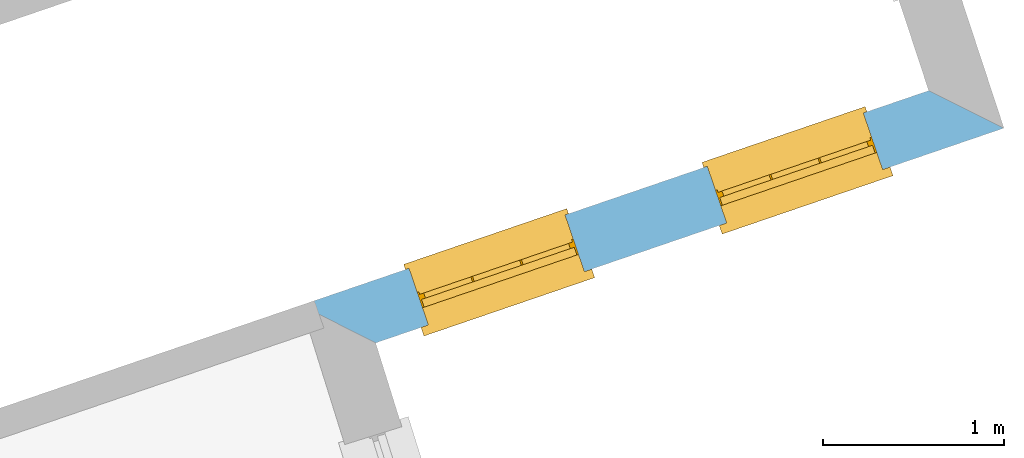
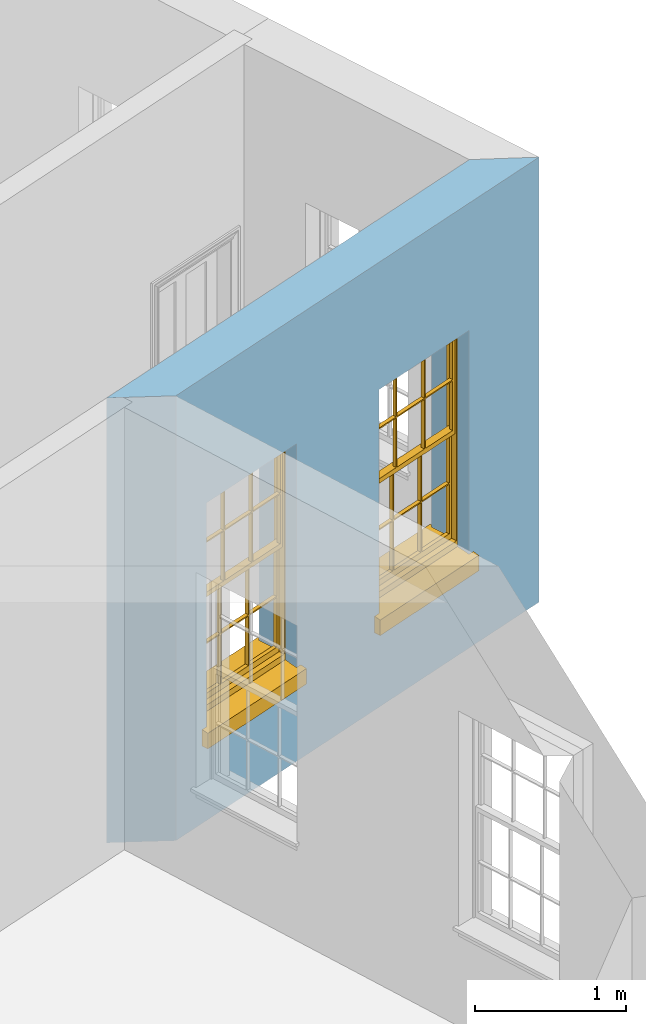
# One storey, part 5 of 10: 2 windows, 2 openings, plus 1 element that does not belong to this part.
"""IFC2X3 building model written with IfcOpenShell, lengths in metres."""

from ifc_helpers import new_model, si_unit, frame, origin, place, context, subcontext, project, spatial, polyline, outline, extrude, faceted_brep, material, layer, layer_set, layer_usage, element, fill, save


model = new_model("IFC2X3")

# Units and contexts
model_context = context("Model", 3, world=origin())
body_context = subcontext(model_context, "Body", "Model", "MODEL_VIEW")
ifc_project = project(units=[si_unit("PLANEANGLEUNIT", "RADIAN"), si_unit("MASSUNIT", "GRAM", prefix="KILO"), si_unit("FORCEUNIT", "NEWTON", prefix="KILO"), si_unit("LENGTHUNIT", "METRE")], contexts=[model_context])

# Site, building, storey
site_placement = place(None, origin())
site = spatial("IfcSite", under=ifc_project, at=site_placement, CompositionType="ELEMENT")
building_placement = place(None, origin())
building = spatial("IfcBuilding", under=site, at=building_placement, Name="Building plot-2", CompositionType="ELEMENT")
storey_placement = place(None, frame((0.0, 0.0, 4.6)))
storey = spatial("IfcBuildingStorey", under=building, at=storey_placement, Name="Floor 1", CompositionType="ELEMENT", Elevation=4.6)

# Wall, openings, windows
ifc_material = material(Name="Masonry")
ifc_layer = layer(ifc_material, 0.33, ventilated=False)
ifc_layer_set = layer_set([ifc_layer], Name="My Wall")
ifc_layer_usage = layer_usage(ifc_layer_set, "AXIS2", "NEGATIVE", 0.08)
wall_placement = place(storey_placement, origin())
wall = element("IfcWallStandardCase", 1, at=wall_placement, inside=storey, material=ifc_layer_usage, Name="exterior", context=body_context, shape_type="SweptSolid", body=[
    extrude(outline(polyline([(33.2298586094676, 32.7296307023118), (33.6407893243681, 32.5213803227765), (37.1047195485034, 33.7057805140381), (36.6893138301649, 33.9125007833851), (33.2298586094676, 32.7296307023118)])), origin(), (0.0, 0.0, 1.0), 3.6),
])
opening_1_placement = place(storey_placement, frame((0.0, 0.0, 0.75)))
opening_1 = element("IfcOpeningElement", 2, at=opening_1_placement, cuts=wall, Name="Opening", ObjectType="Opening", context=body_context, shape_type="SweptSolid", body=[
    extrude(outline(polyline([(33.9307807744007, 32.620535301849), (34.7918378423025, 32.9149512080368), (34.6850716345641, 33.2272026722209), (33.8240145666623, 32.9327867660332), (33.9307807744007, 32.620535301849)])), origin(), (0.0, 0.0, 1.0), 1.82),
])
opening_2_placement = place(storey_placement, frame((0.0, 0.0, 0.75)))
opening_2 = element("IfcOpeningElement", 3, at=opening_2_placement, cuts=wall, Name="Opening", ObjectType="Opening", context=body_context, shape_type="SweptSolid", body=[
    extrude(outline(polyline([(35.5752381859879, 33.1828144318484), (36.4362952538897, 33.4772303380362), (36.3295290461513, 33.7894818022204), (35.4684719782495, 33.4950658960326), (35.5752381859879, 33.1828144318484)])), origin(), (0.0, 0.0, 1.0), 1.82),
])
window_1_placement = place(storey_placement, frame((33.8498972836898, 32.8570894413824, 0.75), z_axis=(0.0, 0.0, 1.0), x_axis=(0.86105706790179, 0.294415906187787, 0.0)))
window_1 = element("IfcWindow", 4, at=window_1_placement, inside=storey, Name="circulation outside window", OverallHeight=1.82, OverallWidth=0.91, context=body_context, shape_type="Brep", held_by="IfcProductRepresentation", body=[
    faceted_brep([(0.033125, -0.105, 0.975209), (0.01, -0.105, 0.975209), (0.033125, -0.105, 1.376042), (0.876875, -0.105, 0.975209), (0.876875, -0.105, 1.376042), (0.9, -0.105, 0.975209), (0.876875, -0.105, 1.386042), (0.876875, -0.105, 1.786875), (0.9, -0.105, 1.81), (0.033125, -0.105, 1.786875), (0.033125, -0.105, 1.386042), (0.01, -0.105, 1.81), (0.876875, -0.135, 1.376042), (0.876875, -0.135, 0.975209), (0.9, -0.135, 0.937083), (0.033125, -0.135, 1.786875), (0.01, -0.135, 1.81), (0.033125, -0.135, 1.386042), (0.01, -0.135, 0.937083), (0.033125, -0.135, 0.975209), (0.033125, -0.135, 1.376042), (0.876875, -0.135, 1.786875), (0.876875, -0.135, 1.386042), (0.9, -0.135, 1.81), (0.033125, -0.105, 0.937083), (0.01, -0.105, 0.937083), (0.033125, -0.105, 0.53625), (0.876875, -0.105, 0.937083), (0.876875, -0.105, 0.53625), (0.9, -0.105, 0.937083), (0.876875, -0.105, 0.52625), (0.876875, -0.105, 0.125417), (0.9, -0.105, 0.077167), (0.033125, -0.105, 0.125417), (0.033125, -0.105, 0.52625), (0.01, -0.105, 0.077167), (-0.0425, -0.25, 0.01), (-0.0425, -0.3, 0.001667), (0.0, -0.25, 0.01), (0.9525, -0.25, 0.01), (0.91, -0.25, 0.01), (0.9525, -0.3, 0.001667), (-0.02, 0.08, 0.077167), (0.0, 0.08, 0.077167), (-0.02, 0.11, 0.077167), (0.0, -0.06, 0.077167), (0.01, -0.06, 0.077167), (0.91, -0.06, 0.077167), (0.91, 0.08, 0.077167), (0.9, -0.06, 0.077167), (0.93, 0.08, 0.077167), (0.93, 0.11, 0.077167), (0.01, -0.075, 0.975209), (0.9, -0.075, 0.975209), (0.876875, -0.075, 0.125417), (0.876875, -0.075, 0.52625), (0.9, -0.075, 0.077167), (0.876875, -0.075, 0.53625), (0.876875, -0.075, 0.937083), (0.033125, -0.075, 0.125417), (0.01, -0.075, 0.077167), (0.033125, -0.075, 0.52625), (0.033125, -0.075, 0.937083), (0.033125, -0.075, 0.53625), (-0.02, 0.08, 0.052167), (-0.02, 0.11, 0.052167), (0.93, 0.11, 0.052167), (0.93, 0.08, 0.052167), (0.91, 0.08, 0.052167), (0.0, 0.08, 0.052167), (0.91, -0.15, 0.026667), (0.0, -0.15, 0.026667), (-0.0425, -0.3, -0.123333), (0.9525, -0.3, -0.123333), (-0.0425, -0.25, -0.123333), (0.9525, -0.25, -0.123333), (0.01, -0.06, 1.81), (0.9, -0.06, 1.81), (0.0, -0.06, 1.82), (0.91, -0.06, 1.82), (0.01, -0.15, 0.077167), (0.9, -0.15, 0.077167), (0.592292, -0.105, 0.125417), (0.592292, -0.075, 0.125417), (0.317708, -0.075, 0.125417), (0.317708, -0.105, 0.125417), (0.592292, -0.105, 0.53625), (0.317708, -0.105, 0.53625), (0.317708, -0.105, 0.52625), (0.592292, -0.105, 0.52625), (0.592292, -0.075, 0.53625), (0.317708, -0.075, 0.53625), (0.592292, -0.135, 1.386042), (0.592292, -0.105, 1.386042), (0.317708, -0.105, 1.386042), (0.317708, -0.135, 1.386042), (0.317708, -0.135, 1.376042), (0.592292, -0.135, 1.376042), (0.317708, -0.105, 1.376042), (0.592292, -0.105, 1.376042), (0.602292, -0.135, 1.376042), (0.592292, -0.135, 0.975209), (0.602292, -0.135, 0.975209), (0.602292, -0.105, 0.975209), (0.592292, -0.105, 0.975209), (0.602292, -0.105, 1.376042), (0.602292, -0.075, 0.53625), (0.602292, -0.105, 0.53625), (0.317708, -0.075, 0.52625), (0.307708, -0.075, 0.125417), (0.307708, -0.075, 0.52625), (0.602292, -0.075, 0.52625), (0.602292, -0.075, 0.125417), (0.592292, -0.075, 0.52625), (0.307708, -0.075, 0.53625), (0.317708, -0.075, 0.937083), (0.307708, -0.075, 0.937083), (0.602292, -0.075, 0.937083), (0.592292, -0.075, 0.937083), (0.307708, -0.105, 0.52625), (0.307708, -0.105, 0.125417), (0.307708, -0.105, 0.53625), (0.307708, -0.105, 0.937083), (0.592292, -0.105, 0.937083), (0.317708, -0.105, 0.937083), (0.602292, -0.105, 0.937083), (0.602292, -0.105, 0.52625), (0.602292, -0.105, 0.125417), (0.307708, -0.135, 1.386042), (0.307708, -0.135, 1.376042), (0.307708, -0.135, 0.975209), (0.317708, -0.135, 0.975209), (0.317708, -0.135, 1.786875), (0.307708, -0.135, 1.786875), (0.602292, -0.135, 1.786875), (0.592292, -0.135, 1.786875), (0.602292, -0.135, 1.386042), (0.602292, -0.105, 1.386042), (0.307708, -0.105, 1.386042), (0.307708, -0.105, 1.786875), (0.317708, -0.105, 1.786875), (0.592292, -0.105, 1.786875), (0.602292, -0.105, 1.786875), (0.307708, -0.105, 1.376042), (0.317708, -0.105, 0.975209), (0.307708, -0.105, 0.975209), (0.91, -0.15, 1.82), (0.9, -0.15, 1.81), (0.01, -0.15, 1.81), (0.0, -0.15, 1.82), (0.91, -0.25, 0.0), (0.0, -0.25, 0.0), (0.91, 0.08, 0.0), (0.0, 0.08, 0.0)], [[[0, 1, 2]], [[3, 4, 5]], [[6, 7, 8]], [[9, 10, 11]], [[12, 13, 14]], [[15, 16, 17]], [[18, 19, 20]], [[21, 22, 23]], [[24, 25, 26]], [[27, 28, 29]], [[30, 31, 32]], [[33, 34, 35]], [[14, 27, 29]], [[25, 24, 18]], [[36, 37, 38]], [[39, 40, 41]], [[42, 43, 44]], [[45, 46, 43]], [[47, 48, 49]], [[50, 51, 48]], [[1, 0, 52]], [[5, 53, 3]], [[54, 55, 56]], [[57, 58, 53]], [[59, 60, 61]], [[62, 63, 52]], [[48, 43, 46, 49]], [[51, 44, 43, 48]], [[64, 42, 44, 65]], [[65, 44, 51, 66]], [[66, 51, 50, 67]], [[65, 66, 68, 69]], [[60, 56, 49, 46]], [[70, 71, 38, 40]], [[37, 41, 40, 38]], [[37, 72, 73, 41]], [[74, 75, 73, 72]], [[8, 11, 76, 77]], [[76, 78, 79, 77]], [[32, 35, 80, 81]], [[81, 80, 71, 70]], [[82, 83, 84, 85]], [[86, 87, 88, 89]], [[86, 90, 91, 87]], [[92, 93, 94, 95]], [[92, 95, 96, 97]], [[96, 98, 99, 97]], [[100, 97, 101, 102]], [[103, 104, 99, 105]], [[97, 99, 104, 101]], [[102, 103, 105, 100]], [[28, 57, 106, 107]], [[108, 84, 109, 110]], [[111, 112, 83, 113]], [[114, 110, 61, 63]], [[90, 113, 108, 91]], [[115, 91, 114, 116]], [[117, 106, 90, 118]], [[111, 106, 57, 55]], [[119, 110, 109, 120]], [[34, 61, 110, 119]], [[89, 113, 83, 82]], [[88, 108, 113, 89]], [[85, 84, 108, 88]], [[121, 114, 63, 26]], [[122, 116, 114, 121]], [[123, 118, 90, 86]], [[87, 91, 115, 124]], [[107, 106, 117, 125]], [[126, 111, 55, 30]], [[127, 112, 111, 126]], [[126, 30, 28, 107]], [[88, 119, 120, 85]], [[126, 89, 82, 127]], [[125, 123, 86, 107]], [[121, 26, 34, 119]], [[124, 122, 121, 87]], [[128, 17, 20, 129]], [[96, 129, 130, 131]], [[132, 133, 128, 95]], [[134, 135, 92, 136]], [[100, 12, 22, 136]], [[137, 6, 4, 105]], [[94, 138, 139, 140]], [[137, 93, 141, 142]], [[99, 98, 94, 93]], [[143, 2, 10, 138]], [[144, 145, 143, 98]], [[129, 143, 145, 130]], [[20, 2, 143, 129]], [[131, 144, 98, 96]], [[128, 138, 10, 17]], [[133, 139, 138, 128]], [[135, 141, 93, 92]], [[95, 94, 140, 132]], [[22, 6, 137, 136]], [[136, 137, 142, 134]], [[100, 105, 4, 12]], [[107, 86, 89, 126]], [[106, 111, 113, 90]], [[91, 108, 110, 114]], [[87, 121, 119, 88]], [[97, 100, 136, 92]], [[129, 96, 95, 128]], [[98, 143, 138, 94]], [[105, 99, 93, 137]], [[131, 101, 104, 144]], [[124, 115, 118, 123]], [[132, 140, 141, 135]], [[120, 109, 59, 33]], [[15, 9, 139, 133]], [[134, 142, 7, 21]], [[31, 54, 112, 127]], [[36, 74, 72, 37]], [[39, 41, 73, 75]], [[18, 14, 101, 131]], [[23, 16, 132, 135]], [[83, 56, 60, 84]], [[52, 53, 118, 115]], [[53, 52, 144, 104]], [[11, 8, 141, 140]], [[14, 18, 124, 123]], [[2, 1, 11, 10]], [[8, 5, 4, 6]], [[57, 53, 56, 55]], [[60, 52, 63, 61]], [[26, 25, 35, 34]], [[32, 29, 28, 30]], [[14, 23, 22, 12]], [[18, 20, 17, 16]], [[19, 0, 2, 20]], [[17, 10, 9, 15]], [[12, 4, 3, 13]], [[21, 7, 6, 22]], [[27, 58, 57, 28]], [[30, 55, 54, 31]], [[33, 59, 61, 34]], [[26, 63, 62, 24]], [[5, 8, 77, 53]], [[76, 11, 1, 52]], [[46, 45, 78, 76]], [[49, 77, 79, 47]], [[70, 146, 147, 81]], [[71, 80, 148, 149]], [[19, 130, 145, 0]], [[102, 13, 3, 103]], [[116, 122, 24, 62]], [[29, 32, 81, 14]], [[80, 35, 25, 18]], [[60, 46, 76, 52]], [[77, 49, 56, 53]], [[23, 14, 81, 147]], [[16, 148, 80, 18]], [[35, 85, 120]], [[120, 33, 35]], [[127, 82, 32]], [[32, 31, 127]], [[32, 82, 85, 35]], [[102, 101, 14]], [[14, 13, 102]], [[18, 131, 130]], [[130, 19, 18]], [[134, 21, 23]], [[23, 135, 134]], [[16, 15, 133]], [[133, 132, 16]], [[11, 140, 139]], [[139, 9, 11]], [[142, 141, 8]], [[8, 7, 142]], [[23, 147, 148, 16]], [[146, 149, 148, 147]], [[52, 115, 116]], [[116, 62, 52]], [[118, 53, 117]], [[58, 117, 53]], [[27, 125, 117, 58]], [[56, 83, 112]], [[112, 54, 56]], [[109, 84, 60]], [[60, 59, 109]], [[125, 27, 14]], [[14, 123, 125]], [[122, 124, 18]], [[18, 24, 122]], [[145, 144, 52]], [[52, 0, 145]], [[103, 3, 53]], [[53, 104, 103]], [[79, 78, 149, 146]], [[78, 45, 71, 149]], [[146, 70, 47, 79]], [[150, 75, 74, 151]], [[68, 66, 67]], [[48, 68, 67, 50]], [[69, 64, 65]], [[42, 64, 69, 43]], [[69, 68, 152, 153]], [[70, 68, 48, 47]], [[150, 152, 68, 70]], [[43, 69, 71, 45]], [[69, 153, 151, 71]], [[152, 150, 151, 153]], [[38, 151, 74, 36]], [[71, 151, 38]], [[39, 75, 150, 40]], [[40, 150, 70]]]),
])
fill(opening_1, window_1)
window_2_placement = place(storey_placement, frame((35.494354695277, 33.4193685713819, 0.75), z_axis=(0.0, 0.0, 1.0), x_axis=(0.86105706790179, 0.294415906187794, 0.0)))
window_2 = element("IfcWindow", 5, at=window_2_placement, inside=storey, Name="circulation outside window", OverallHeight=1.82, OverallWidth=0.91, context=body_context, shape_type="Brep", held_by="IfcProductRepresentation", body=[
    faceted_brep([(0.033125, -0.105, 0.975209), (0.01, -0.105, 0.975209), (0.033125, -0.105, 1.376042), (0.876875, -0.105, 0.975209), (0.876875, -0.105, 1.376042), (0.9, -0.105, 0.975209), (0.876875, -0.105, 1.386042), (0.876875, -0.105, 1.786875), (0.9, -0.105, 1.81), (0.033125, -0.105, 1.786875), (0.033125, -0.105, 1.386042), (0.01, -0.105, 1.81), (0.876875, -0.135, 1.376042), (0.876875, -0.135, 0.975209), (0.9, -0.135, 0.937083), (0.033125, -0.135, 1.786875), (0.01, -0.135, 1.81), (0.033125, -0.135, 1.386042), (0.01, -0.135, 0.937083), (0.033125, -0.135, 0.975209), (0.033125, -0.135, 1.376042), (0.876875, -0.135, 1.786875), (0.876875, -0.135, 1.386042), (0.9, -0.135, 1.81), (0.033125, -0.105, 0.937083), (0.01, -0.105, 0.937083), (0.033125, -0.105, 0.53625), (0.876875, -0.105, 0.937083), (0.876875, -0.105, 0.53625), (0.9, -0.105, 0.937083), (0.876875, -0.105, 0.52625), (0.876875, -0.105, 0.125417), (0.9, -0.105, 0.077167), (0.033125, -0.105, 0.125417), (0.033125, -0.105, 0.52625), (0.01, -0.105, 0.077167), (-0.0425, -0.25, 0.01), (-0.0425, -0.3, 0.001667), (0.0, -0.25, 0.01), (0.9525, -0.25, 0.01), (0.91, -0.25, 0.01), (0.9525, -0.3, 0.001667), (-0.02, 0.08, 0.077167), (0.0, 0.08, 0.077167), (-0.02, 0.11, 0.077167), (0.0, -0.06, 0.077167), (0.01, -0.06, 0.077167), (0.91, -0.06, 0.077167), (0.91, 0.08, 0.077167), (0.9, -0.06, 0.077167), (0.93, 0.08, 0.077167), (0.93, 0.11, 0.077167), (0.01, -0.075, 0.975209), (0.9, -0.075, 0.975209), (0.876875, -0.075, 0.125417), (0.876875, -0.075, 0.52625), (0.9, -0.075, 0.077167), (0.876875, -0.075, 0.53625), (0.876875, -0.075, 0.937083), (0.033125, -0.075, 0.125417), (0.01, -0.075, 0.077167), (0.033125, -0.075, 0.52625), (0.033125, -0.075, 0.937083), (0.033125, -0.075, 0.53625), (-0.02, 0.08, 0.052167), (-0.02, 0.11, 0.052167), (0.93, 0.11, 0.052167), (0.93, 0.08, 0.052167), (0.91, 0.08, 0.052167), (0.0, 0.08, 0.052167), (0.91, -0.15, 0.026667), (0.0, -0.15, 0.026667), (-0.0425, -0.3, -0.123333), (0.9525, -0.3, -0.123333), (-0.0425, -0.25, -0.123333), (0.9525, -0.25, -0.123333), (0.01, -0.06, 1.81), (0.9, -0.06, 1.81), (0.0, -0.06, 1.82), (0.91, -0.06, 1.82), (0.01, -0.15, 0.077167), (0.9, -0.15, 0.077167), (0.592292, -0.105, 0.125417), (0.592292, -0.075, 0.125417), (0.317708, -0.075, 0.125417), (0.317708, -0.105, 0.125417), (0.592292, -0.105, 0.53625), (0.317708, -0.105, 0.53625), (0.317708, -0.105, 0.52625), (0.592292, -0.105, 0.52625), (0.592292, -0.075, 0.53625), (0.317708, -0.075, 0.53625), (0.592292, -0.135, 1.386042), (0.592292, -0.105, 1.386042), (0.317708, -0.105, 1.386042), (0.317708, -0.135, 1.386042), (0.317708, -0.135, 1.376042), (0.592292, -0.135, 1.376042), (0.317708, -0.105, 1.376042), (0.592292, -0.105, 1.376042), (0.602292, -0.135, 1.376042), (0.592292, -0.135, 0.975209), (0.602292, -0.135, 0.975209), (0.602292, -0.105, 0.975209), (0.592292, -0.105, 0.975209), (0.602292, -0.105, 1.376042), (0.602292, -0.075, 0.53625), (0.602292, -0.105, 0.53625), (0.317708, -0.075, 0.52625), (0.307708, -0.075, 0.125417), (0.307708, -0.075, 0.52625), (0.602292, -0.075, 0.52625), (0.602292, -0.075, 0.125417), (0.592292, -0.075, 0.52625), (0.307708, -0.075, 0.53625), (0.317708, -0.075, 0.937083), (0.307708, -0.075, 0.937083), (0.602292, -0.075, 0.937083), (0.592292, -0.075, 0.937083), (0.307708, -0.105, 0.52625), (0.307708, -0.105, 0.125417), (0.307708, -0.105, 0.53625), (0.307708, -0.105, 0.937083), (0.592292, -0.105, 0.937083), (0.317708, -0.105, 0.937083), (0.602292, -0.105, 0.937083), (0.602292, -0.105, 0.52625), (0.602292, -0.105, 0.125417), (0.307708, -0.135, 1.386042), (0.307708, -0.135, 1.376042), (0.307708, -0.135, 0.975209), (0.317708, -0.135, 0.975209), (0.317708, -0.135, 1.786875), (0.307708, -0.135, 1.786875), (0.602292, -0.135, 1.786875), (0.592292, -0.135, 1.786875), (0.602292, -0.135, 1.386042), (0.602292, -0.105, 1.386042), (0.307708, -0.105, 1.386042), (0.307708, -0.105, 1.786875), (0.317708, -0.105, 1.786875), (0.592292, -0.105, 1.786875), (0.602292, -0.105, 1.786875), (0.307708, -0.105, 1.376042), (0.317708, -0.105, 0.975209), (0.307708, -0.105, 0.975209), (0.91, -0.15, 1.82), (0.9, -0.15, 1.81), (0.01, -0.15, 1.81), (0.0, -0.15, 1.82), (0.91, -0.25, 0.0), (0.0, -0.25, 0.0), (0.91, 0.08, 0.0), (0.0, 0.08, 0.0)], [[[0, 1, 2]], [[3, 4, 5]], [[6, 7, 8]], [[9, 10, 11]], [[12, 13, 14]], [[15, 16, 17]], [[18, 19, 20]], [[21, 22, 23]], [[24, 25, 26]], [[27, 28, 29]], [[30, 31, 32]], [[33, 34, 35]], [[14, 27, 29]], [[25, 24, 18]], [[36, 37, 38]], [[39, 40, 41]], [[42, 43, 44]], [[45, 46, 43]], [[47, 48, 49]], [[50, 51, 48]], [[1, 0, 52]], [[5, 53, 3]], [[54, 55, 56]], [[57, 58, 53]], [[59, 60, 61]], [[62, 63, 52]], [[48, 43, 46, 49]], [[51, 44, 43, 48]], [[64, 42, 44, 65]], [[65, 44, 51, 66]], [[66, 51, 50, 67]], [[65, 66, 68, 69]], [[60, 56, 49, 46]], [[70, 71, 38, 40]], [[37, 41, 40, 38]], [[37, 72, 73, 41]], [[74, 75, 73, 72]], [[8, 11, 76, 77]], [[76, 78, 79, 77]], [[32, 35, 80, 81]], [[81, 80, 71, 70]], [[82, 83, 84, 85]], [[86, 87, 88, 89]], [[86, 90, 91, 87]], [[92, 93, 94, 95]], [[92, 95, 96, 97]], [[96, 98, 99, 97]], [[100, 97, 101, 102]], [[103, 104, 99, 105]], [[97, 99, 104, 101]], [[102, 103, 105, 100]], [[28, 57, 106, 107]], [[108, 84, 109, 110]], [[111, 112, 83, 113]], [[114, 110, 61, 63]], [[90, 113, 108, 91]], [[115, 91, 114, 116]], [[117, 106, 90, 118]], [[111, 106, 57, 55]], [[119, 110, 109, 120]], [[34, 61, 110, 119]], [[89, 113, 83, 82]], [[88, 108, 113, 89]], [[85, 84, 108, 88]], [[121, 114, 63, 26]], [[122, 116, 114, 121]], [[123, 118, 90, 86]], [[87, 91, 115, 124]], [[107, 106, 117, 125]], [[126, 111, 55, 30]], [[127, 112, 111, 126]], [[126, 30, 28, 107]], [[88, 119, 120, 85]], [[126, 89, 82, 127]], [[125, 123, 86, 107]], [[121, 26, 34, 119]], [[124, 122, 121, 87]], [[128, 17, 20, 129]], [[96, 129, 130, 131]], [[132, 133, 128, 95]], [[134, 135, 92, 136]], [[100, 12, 22, 136]], [[137, 6, 4, 105]], [[94, 138, 139, 140]], [[137, 93, 141, 142]], [[99, 98, 94, 93]], [[143, 2, 10, 138]], [[144, 145, 143, 98]], [[129, 143, 145, 130]], [[20, 2, 143, 129]], [[131, 144, 98, 96]], [[128, 138, 10, 17]], [[133, 139, 138, 128]], [[135, 141, 93, 92]], [[95, 94, 140, 132]], [[22, 6, 137, 136]], [[136, 137, 142, 134]], [[100, 105, 4, 12]], [[107, 86, 89, 126]], [[106, 111, 113, 90]], [[91, 108, 110, 114]], [[87, 121, 119, 88]], [[97, 100, 136, 92]], [[129, 96, 95, 128]], [[98, 143, 138, 94]], [[105, 99, 93, 137]], [[131, 101, 104, 144]], [[124, 115, 118, 123]], [[132, 140, 141, 135]], [[120, 109, 59, 33]], [[15, 9, 139, 133]], [[134, 142, 7, 21]], [[31, 54, 112, 127]], [[36, 74, 72, 37]], [[39, 41, 73, 75]], [[18, 14, 101, 131]], [[23, 16, 132, 135]], [[83, 56, 60, 84]], [[52, 53, 118, 115]], [[53, 52, 144, 104]], [[11, 8, 141, 140]], [[14, 18, 124, 123]], [[2, 1, 11, 10]], [[8, 5, 4, 6]], [[57, 53, 56, 55]], [[60, 52, 63, 61]], [[26, 25, 35, 34]], [[32, 29, 28, 30]], [[14, 23, 22, 12]], [[18, 20, 17, 16]], [[19, 0, 2, 20]], [[17, 10, 9, 15]], [[12, 4, 3, 13]], [[21, 7, 6, 22]], [[27, 58, 57, 28]], [[30, 55, 54, 31]], [[33, 59, 61, 34]], [[26, 63, 62, 24]], [[5, 8, 77, 53]], [[76, 11, 1, 52]], [[46, 45, 78, 76]], [[49, 77, 79, 47]], [[70, 146, 147, 81]], [[71, 80, 148, 149]], [[19, 130, 145, 0]], [[102, 13, 3, 103]], [[116, 122, 24, 62]], [[29, 32, 81, 14]], [[80, 35, 25, 18]], [[60, 46, 76, 52]], [[77, 49, 56, 53]], [[23, 14, 81, 147]], [[16, 148, 80, 18]], [[35, 85, 120]], [[120, 33, 35]], [[127, 82, 32]], [[32, 31, 127]], [[32, 82, 85, 35]], [[102, 101, 14]], [[14, 13, 102]], [[18, 131, 130]], [[130, 19, 18]], [[134, 21, 23]], [[23, 135, 134]], [[16, 15, 133]], [[133, 132, 16]], [[11, 140, 139]], [[139, 9, 11]], [[142, 141, 8]], [[8, 7, 142]], [[23, 147, 148, 16]], [[146, 149, 148, 147]], [[52, 115, 116]], [[116, 62, 52]], [[118, 53, 117]], [[58, 117, 53]], [[27, 125, 117, 58]], [[56, 83, 112]], [[112, 54, 56]], [[109, 84, 60]], [[60, 59, 109]], [[125, 27, 14]], [[14, 123, 125]], [[122, 124, 18]], [[18, 24, 122]], [[145, 144, 52]], [[52, 0, 145]], [[103, 3, 53]], [[53, 104, 103]], [[79, 78, 149, 146]], [[78, 45, 71, 149]], [[146, 70, 47, 79]], [[150, 75, 74, 151]], [[68, 66, 67]], [[48, 68, 67, 50]], [[69, 64, 65]], [[42, 64, 69, 43]], [[69, 68, 152, 153]], [[70, 68, 48, 47]], [[150, 152, 68, 70]], [[43, 69, 71, 45]], [[69, 153, 151, 71]], [[152, 150, 151, 153]], [[38, 151, 74, 36]], [[71, 151, 38]], [[39, 75, 150, 40]], [[40, 150, 70]]]),
])
fill(opening_2, window_2)

save(model, "model.ifc")
